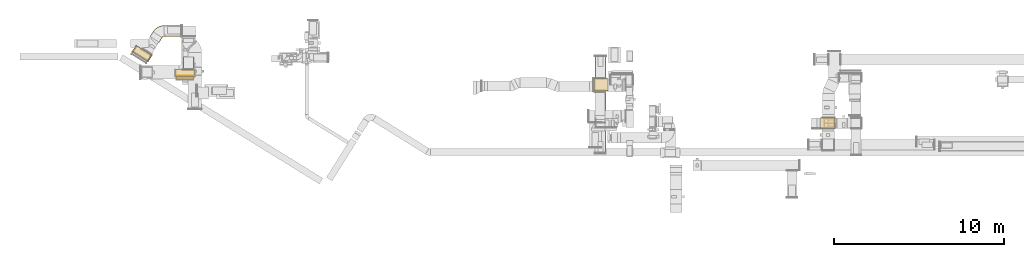
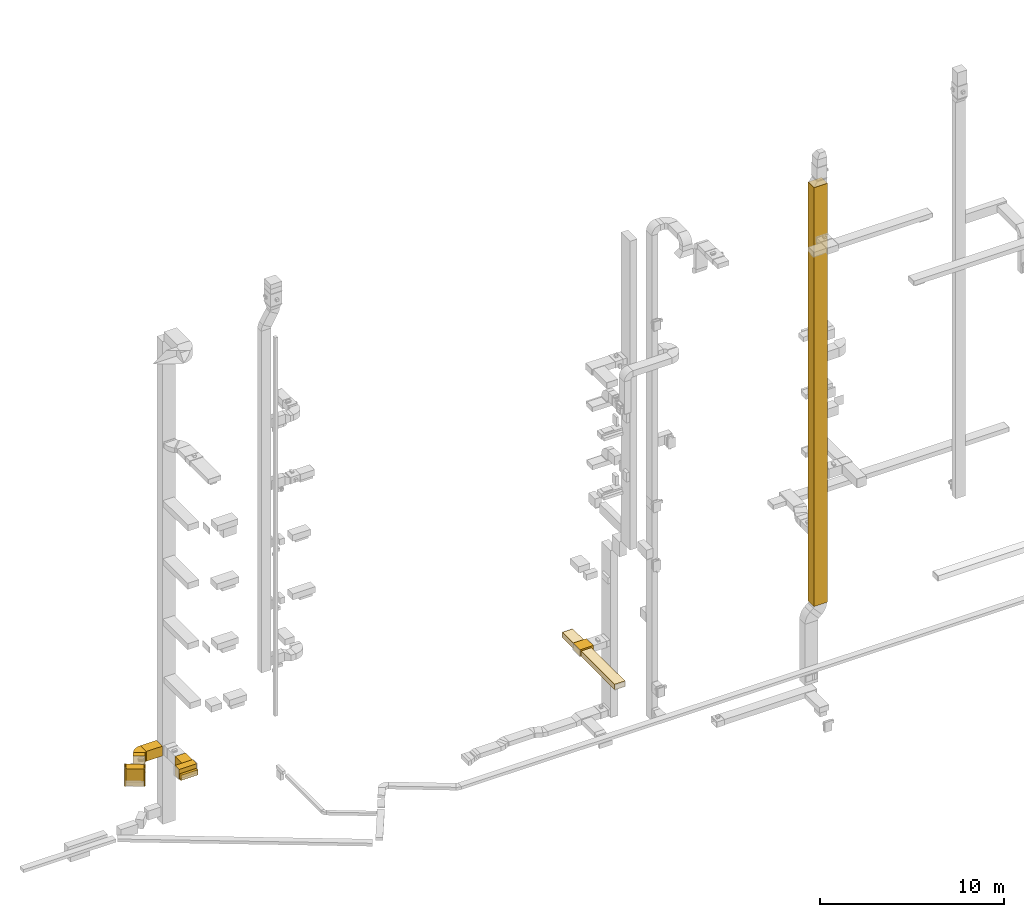
# One storey, part 1 of 25: 14 coverings.
"""IFC2X3 building model written with IfcOpenShell, lengths in millimetres."""

from ifc_helpers import new_model, entity, si_unit, converted_unit, derived_unit, direction, frame, frame_2d, origin, origin_2d_with_axis, place, context, subcontext, project, spatial, polyline, circle_curve, parameter, trimmed, segment, composite_curve, rectangle, outline, extrude, element, save


model = new_model("IFC2X3")

# Units and contexts
model_context = context("Model", 3, precision=0.01, world=origin(), true_north=direction((6.12303176911189e-17, 1.0)))
body_context = subcontext(model_context, "Body", "Model", "MODEL_VIEW")
ifc_project = project(units=[si_unit("LENGTHUNIT", "METRE", prefix="MILLI"), si_unit("AREAUNIT", "SQUARE_METRE"), si_unit("VOLUMEUNIT", "CUBIC_METRE"), converted_unit("PLANEANGLEUNIT", "DEGREE", entity("IfcRatioMeasure", 0.0174532925199433), si_unit("PLANEANGLEUNIT", "RADIAN"), dimensions=[0, 0, 0, 0, 0, 0, 0]), si_unit("MASSUNIT", "GRAM", prefix="KILO"), derived_unit("MASSDENSITYUNIT", [(si_unit("MASSUNIT", "GRAM", prefix="KILO"), 1), (si_unit("LENGTHUNIT", "METRE"), -3)]), derived_unit("MOMENTOFINERTIAUNIT", [(si_unit("LENGTHUNIT", "METRE"), 4)]), si_unit("TIMEUNIT", "SECOND"), si_unit("FREQUENCYUNIT", "HERTZ"), si_unit("THERMODYNAMICTEMPERATUREUNIT", "DEGREE_CELSIUS"), derived_unit("THERMALTRANSMITTANCEUNIT", [(si_unit("MASSUNIT", "GRAM", prefix="KILO"), 1), (si_unit("THERMODYNAMICTEMPERATUREUNIT", "KELVIN"), -1), (si_unit("TIMEUNIT", "SECOND"), -3)]), derived_unit("VOLUMETRICFLOWRATEUNIT", [(si_unit("LENGTHUNIT", "METRE"), 3), (si_unit("TIMEUNIT", "SECOND"), -1)]), derived_unit("MASSFLOWRATEUNIT", [(si_unit("MASSUNIT", "GRAM", prefix="KILO"), 1), (si_unit("TIMEUNIT", "SECOND"), -1)]), derived_unit("ROTATIONALFREQUENCYUNIT", [(si_unit("TIMEUNIT", "SECOND"), -1)]), si_unit("ELECTRICCURRENTUNIT", "AMPERE"), si_unit("ELECTRICVOLTAGEUNIT", "VOLT"), si_unit("POWERUNIT", "WATT"), si_unit("FORCEUNIT", "NEWTON", prefix="KILO"), si_unit("ILLUMINANCEUNIT", "LUX"), si_unit("LUMINOUSFLUXUNIT", "LUMEN"), si_unit("LUMINOUSINTENSITYUNIT", "CANDELA"), derived_unit("USERDEFINED", [(si_unit("MASSUNIT", "GRAM", prefix="KILO"), -1), (si_unit("LENGTHUNIT", "METRE"), -2), (si_unit("TIMEUNIT", "SECOND"), 3), (si_unit("LUMINOUSFLUXUNIT", "LUMEN"), 1)]), derived_unit("LINEARVELOCITYUNIT", [(si_unit("LENGTHUNIT", "METRE"), 1), (si_unit("TIMEUNIT", "SECOND"), -1)]), si_unit("PRESSUREUNIT", "PASCAL"), derived_unit("USERDEFINED", [(si_unit("LENGTHUNIT", "METRE"), -2), (si_unit("MASSUNIT", "GRAM", prefix="KILO"), 1), (si_unit("TIMEUNIT", "SECOND"), -2)]), derived_unit("LINEARFORCEUNIT", [(si_unit("MASSUNIT", "GRAM", prefix="KILO"), 1), (si_unit("LENGTHUNIT", "METRE"), 1), (si_unit("TIMEUNIT", "SECOND"), -2), (si_unit("LENGTHUNIT", "METRE"), -1)]), derived_unit("PLANARFORCEUNIT", [(si_unit("MASSUNIT", "GRAM", prefix="KILO"), 1), (si_unit("LENGTHUNIT", "METRE"), 1), (si_unit("TIMEUNIT", "SECOND"), -2), (si_unit("LENGTHUNIT", "METRE"), -2)])], contexts=[model_context])

# Site, building, storey
site_placement = place(None, origin())
site = spatial("IfcSite", under=ifc_project, at=site_placement, CompositionType="ELEMENT")
building_placement = place(site_placement, origin())
building = spatial("IfcBuilding", under=site, at=building_placement, CompositionType="ELEMENT")
storey_placement = place(building_placement, origin())
storey = spatial("IfcBuildingStorey", under=building, at=storey_placement, CompositionType="ELEMENT", Elevation=0.0)

# Coverings
covering_1_placement = place(storey_placement, frame((28415.0, 12772.72, 2475.0)))
element("IfcCovering", 1, at=covering_1_placement, inside=storey, PredefinedType="INSULATION", context=body_context, shape_type="SweptSolid", body=[
    extrude(rectangle(XDim=825.107316474216, YDim=749.999999999998, at=origin_2d_with_axis()), frame((412.55, 375.0, 0.0), z_axis=(0.0, 0.0, 1.0), x_axis=(-1.0, 0.0, 0.0)), (0.0, 0.0, 1.0), 449.999999999999),
])
covering_2_placement = place(storey_placement, frame((28476.05, 13517.72, 2475.0)))
element("IfcCovering", 2, at=covering_2_placement, inside=storey, PredefinedType="INSULATION", context=body_context, shape_type="SweptSolid", body=[
    extrude(rectangle(XDim=1299.51814618853, YDim=650.0, at=origin_2d_with_axis()), frame((325.0, 649.76, 0.0), z_axis=(0.0, 0.0, 1.0), x_axis=(0.0, 1.0, 0.0)), (0.0, 0.0, 1.0), 350.000000000001),
])
covering_3_placement = place(storey_placement, frame((28464.1, 9142.08, 2475.0)))
element("IfcCovering", 3, at=covering_3_placement, inside=storey, PredefinedType="INSULATION", context=body_context, shape_type="SweptSolid", body=[
    extrude(rectangle(XDim=3635.64597304317, YDim=650.0, at=origin_2d_with_axis()), frame((325.0, 1817.82, 0.0), z_axis=(0.0, 0.0, 1.0), x_axis=(0.0, -1.0, 0.0)), (0.0, 0.0, 1.0), 350.000000000001),
])
covering_4_placement = place(storey_placement, frame((4213.74, 14052.5, 2475.0)))
element("IfcCovering", 4, at=covering_4_placement, inside=storey, PredefinedType="INSULATION", context=body_context, shape_type="SweptSolid", body=[
    extrude(rectangle(XDim=738.844290776113, YDim=650.0, at=origin_2d_with_axis()), frame((325.0, 369.42, 0.0), z_axis=(0.0, 0.0, 1.0), x_axis=(0.0, -1.0, 0.0)), (0.0, 0.0, 1.0), 650.000000000001),
])
covering_5_placement = place(storey_placement, frame((3813.74, 13450.1, 2475.0)))
element("IfcCovering", 5, at=covering_5_placement, inside=storey, PredefinedType="INSULATION", context=body_context, shape_type="SweptSolid", body=[
    extrude(rectangle(XDim=162.39827932573, YDim=1050.0, at=origin_2d_with_axis()), frame((525.0, 81.2, 0.0), z_axis=(0.0, 0.0, 1.0), x_axis=(0.0, 1.0, 0.0)), (0.0, 0.0, 1.0), 349.999999999999),
])
covering_6_placement = place(storey_placement, frame((3785.85, 13607.5, 2475.0)))
element("IfcCovering", 6, at=covering_6_placement, inside=storey, PredefinedType="INSULATION", context=body_context, shape_type="SweptSolid", body=[
    extrude(rectangle(XDim=1100.0, YDim=450.000000000002, at=origin_2d_with_axis()), frame((550.0, 225.0, 0.0)), (0.0, 0.0, 1.0), 650.000000000001),
])
covering_7_placement = place(storey_placement, frame((3813.74, 13612.5, 2475.0)))
element("IfcCovering", 7, at=covering_7_placement, inside=storey, PredefinedType="INSULATION", context=body_context, shape_type="SweptSolid", body=[
    extrude(rectangle(XDim=1050.0, YDim=51.0959999999994, at=origin_2d_with_axis()), frame((525.0, 25.55, 0.0)), (0.0, 0.0, 1.0), 349.999999999999),
])
covering_8_placement = place(storey_placement, frame((1272.46, 14529.85, 2025.0)))
element("IfcCovering", 8, at=covering_8_placement, inside=storey, PredefinedType="INSULATION", context=body_context, shape_type="SweptSolid", body=[
    extrude(rectangle(XDim=1000.0, YDim=449.999999999999, at=origin_2d_with_axis()), frame((543.26, 455.77, 0.0), z_axis=(0.0, 0.0, 1.0), x_axis=(0.848048096097044, -0.529919264328235, 0.0)), (0.0, 0.0, 1.0), 1150.0),
])
covering_9_placement = place(storey_placement, frame((1230.06, 15059.77, 2025.0)))
element("IfcCovering", 9, at=covering_9_placement, inside=storey, PredefinedType="INSULATION", context=body_context, shape_type="SweptSolid", body=[
    extrude(rectangle(XDim=50.0000000000009, YDim=450.0, at=origin_2d_with_axis()), frame((140.43, 204.06, 0.0), z_axis=(0.0, 0.0, 1.0), x_axis=(0.848048096097048, -0.52991926432823, 0.0)), (0.0, 0.0, 1.0), 1150.0),
])
covering_10_placement = place(storey_placement, frame((3108.62, 15984.98, 2460.0)))
element("IfcCovering", 10, at=covering_10_placement, inside=storey, PredefinedType="INSULATION", context=body_context, shape_type="SweptSolid", body=[
    extrude(rectangle(XDim=1014.71471811025, YDim=650.0, at=origin_2d_with_axis()), frame((507.36, 325.0, 0.0), z_axis=(0.0, 0.0, 1.0), x_axis=(-1.0, 0.0, 0.0)), (0.0, 0.0, 1.0), 650.000000000001),
])
covering_11_placement = place(storey_placement, frame((2276.07, 15645.67, 2460.0)))
element("IfcCovering", 11, at=covering_11_placement, inside=storey, PredefinedType="INSULATION", context=body_context, shape_type="SweptSolid", body=[
    extrude(rectangle(XDim=330.818571009889, YDim=649.999999999998, at=origin_2d_with_axis()), frame((363.27, 312.5, 0.0), z_axis=(0.0, 0.0, 1.0), x_axis=(-0.529919264328237, -0.848048096097043, 0.0)), (0.0, 0.0, 1.0), 649.999999999999),
])
covering_12_placement = place(storey_placement, frame((2120.51, 14503.36, 2025.0)))
element("IfcCovering", 12, at=covering_12_placement, inside=storey, PredefinedType="INSULATION", context=body_context, shape_type="SweptSolid", body=[
    extrude(rectangle(XDim=50.0000000000007, YDim=450.0, at=origin_2d_with_axis()), frame((140.43, 204.06, 0.0), z_axis=(0.0, 0.0, 1.0), x_axis=(-0.848048096097046, 0.529919264328233, 0.0)), (0.0, 0.0, 1.0), 1150.0),
])
covering_13_placement = place(storey_placement, frame((41759.87, 10559.99, 2454.5)))
element("IfcCovering", 13, at=covering_13_placement, inside=storey, PredefinedType="INSULATION", context=body_context, shape_type="SweptSolid", body=[
    extrude(rectangle(XDim=849.999999999997, YDim=650.0, at=origin_2d_with_axis()), frame((425.0, 325.0, 0.0), z_axis=(0.0, 0.0, 1.0), x_axis=(-1.0, 0.0, 0.0)), (0.0, 0.0, 1.0), 27715.1242230804),
])
covering_14_placement = place(storey_placement, frame((2449.78, 15924.62, 2460.0)))
element("IfcCovering", 14, at=covering_14_placement, inside=storey, PredefinedType="INSULATION", context=body_context, shape_type="SweptSolid", body=[
    extrude(outline(composite_curve([segment(polyline([(-277.99, 84.8), (66.46, -466.43)]), True, "CONTINUOUS"), segment(trimmed(circle_curve(frame_2d((-344.23, 190.81), x_axis=(1.0, 0.0)), 775.0), [parameter(302.000000006421)], [parameter(0.0)], True, "PARAMETER"), True, "CONTINUOUS"), segment(polyline([(430.77, 190.81), (-219.23, 190.81)]), True, "CONTINUOUS"), segment(trimmed(circle_curve(frame_2d((-344.23, 190.81), x_axis=(1.0, 0.0)), 125.0), [parameter(302.00000000642)], [parameter(360.0)], True, "PARAMETER"), False, "CONTINUOUS")], self_intersect=False)), frame((468.02, 279.59, 0.0), z_axis=(0.0, 0.0, -1.0), x_axis=(0.0, 1.0, 0.0)), (0.0, 0.0, -1.0), 650.0),
])

save(model, "model.ifc")
